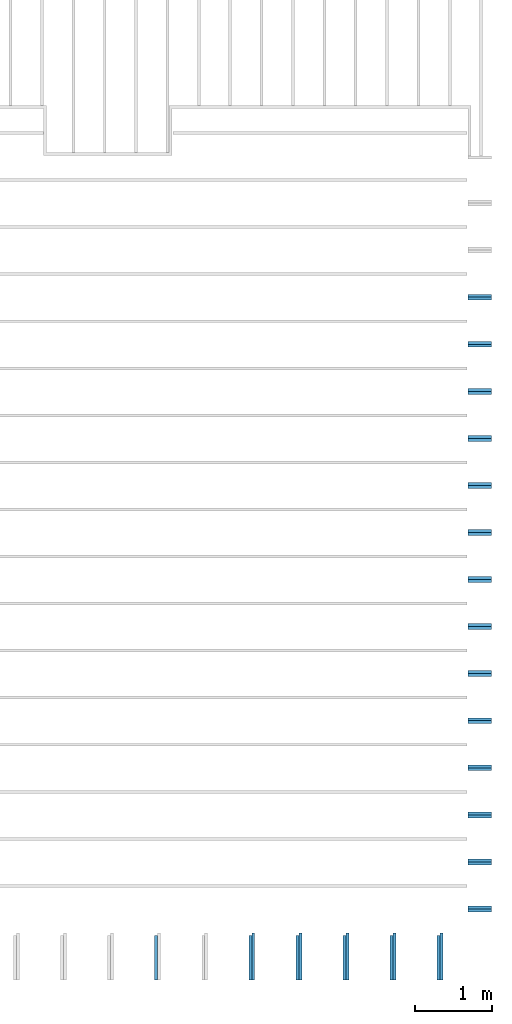
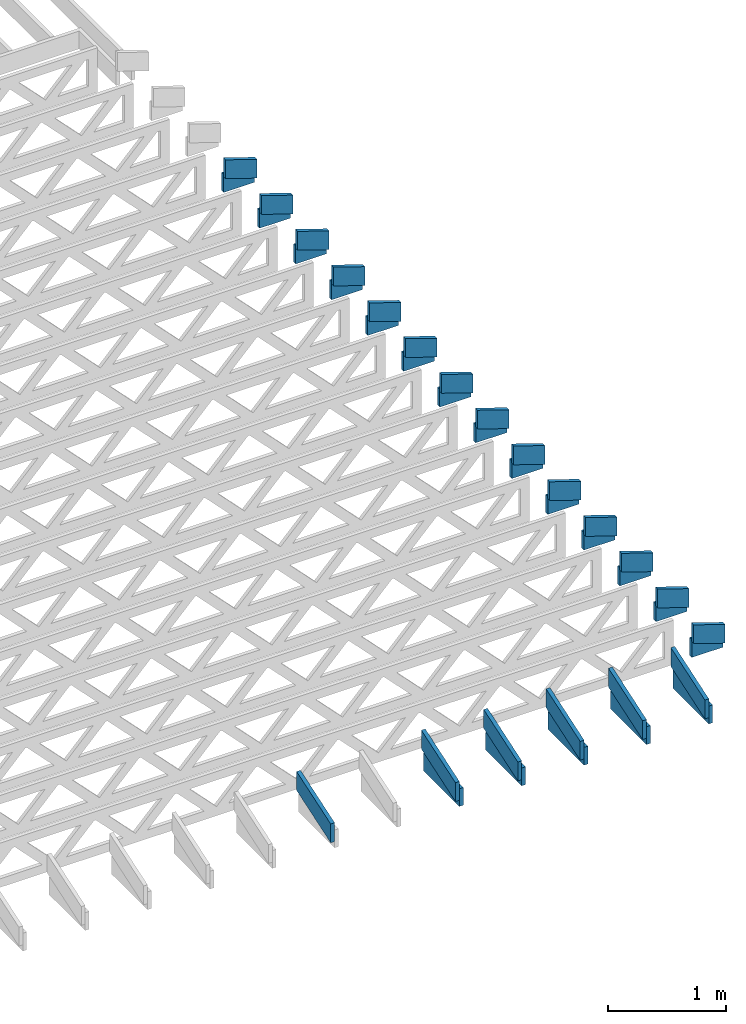
# One storey, part 16 of 18: 39 beams, 4 elements without a shape of their own.
"""IFC4 building model written with IfcOpenShell, lengths in feet."""

from ifc_helpers import new_model, entity, si_unit, converted_unit, derived_unit, direction, frame, frame_2d, origin, origin_2d_with_axis, place, context, subcontext, project, spatial, rectangle, extrude, clip, halfspace, source, transform, mapped, material, material_profile, profile_set, profile_usage, type_object, type_shapes, element, aggregate, save


model = new_model("IFC4")

# Units and contexts
model_context_1 = context("Model", 3, precision=0.0001, world=origin(), true_north=direction((6.12303176911189e-17, 1.0)))
model_context_2 = context("Model", 3, precision=0.0001, world=origin(), true_north=direction((6.12303176911189e-17, 1.0)))
body_context = subcontext(model_context_2, "Body", "Model", "MODEL_VIEW")
ifc_project = project(units=[converted_unit("LENGTHUNIT", "FOOT", entity("IfcRatioMeasure", 0.3048), si_unit("LENGTHUNIT", "METRE"), dimensions=[1, 0, 0, 0, 0, 0, 0]), converted_unit("AREAUNIT", "SQUARE FOOT", entity("IfcRatioMeasure", 0.09290304), si_unit("AREAUNIT", "SQUARE_METRE"), dimensions=[2, 0, 0, 0, 0, 0, 0]), converted_unit("VOLUMEUNIT", "CUBIC FOOT", entity("IfcRatioMeasure", 0.028316846592), si_unit("VOLUMEUNIT", "CUBIC_METRE"), dimensions=[3, 0, 0, 0, 0, 0, 0]), converted_unit("PLANEANGLEUNIT", "DEGREE", entity("IfcRatioMeasure", 0.0174532925199433), si_unit("PLANEANGLEUNIT", "RADIAN"), dimensions=[0, 0, 0, 0, 0, 0, 0]), si_unit("MASSUNIT", "GRAM", prefix="KILO"), derived_unit("MASSDENSITYUNIT", [(si_unit("MASSUNIT", "GRAM", prefix="KILO"), 1), (si_unit("LENGTHUNIT", "METRE"), -3)]), derived_unit("MOMENTOFINERTIAUNIT", [(si_unit("LENGTHUNIT", "METRE"), 4)]), si_unit("TIMEUNIT", "SECOND"), si_unit("FREQUENCYUNIT", "HERTZ"), si_unit("THERMODYNAMICTEMPERATUREUNIT", "DEGREE_CELSIUS"), derived_unit("THERMALTRANSMITTANCEUNIT", [(si_unit("MASSUNIT", "GRAM", prefix="KILO"), 1), (si_unit("THERMODYNAMICTEMPERATUREUNIT", "KELVIN"), -1), (si_unit("TIMEUNIT", "SECOND"), -3)]), derived_unit("VOLUMETRICFLOWRATEUNIT", [(si_unit("LENGTHUNIT", "METRE"), 3), (si_unit("TIMEUNIT", "SECOND"), -1)]), si_unit("ELECTRICCURRENTUNIT", "AMPERE"), si_unit("ELECTRICVOLTAGEUNIT", "VOLT"), si_unit("POWERUNIT", "WATT"), si_unit("FORCEUNIT", "NEWTON"), si_unit("ILLUMINANCEUNIT", "LUX"), si_unit("LUMINOUSFLUXUNIT", "LUMEN"), si_unit("LUMINOUSINTENSITYUNIT", "CANDELA"), derived_unit("USERDEFINED", [(si_unit("MASSUNIT", "GRAM", prefix="KILO"), -1), (si_unit("LENGTHUNIT", "METRE"), -2), (si_unit("TIMEUNIT", "SECOND"), 3), (si_unit("LUMINOUSFLUXUNIT", "LUMEN"), 1)]), derived_unit("LINEARVELOCITYUNIT", [(si_unit("LENGTHUNIT", "METRE"), 1), (si_unit("TIMEUNIT", "SECOND"), -1)]), si_unit("PRESSUREUNIT", "PASCAL"), derived_unit("USERDEFINED", [(si_unit("LENGTHUNIT", "METRE"), -2), (si_unit("MASSUNIT", "GRAM", prefix="KILO"), 1), (si_unit("TIMEUNIT", "SECOND"), -2)]), derived_unit("LINEARFORCEUNIT", [(si_unit("MASSUNIT", "GRAM", prefix="KILO"), 1), (si_unit("LENGTHUNIT", "METRE"), 1), (si_unit("TIMEUNIT", "SECOND"), -2), (si_unit("LENGTHUNIT", "METRE"), -1)]), derived_unit("PLANARFORCEUNIT", [(si_unit("MASSUNIT", "GRAM", prefix="KILO"), 1), (si_unit("LENGTHUNIT", "METRE"), 1), (si_unit("TIMEUNIT", "SECOND"), -2), (si_unit("LENGTHUNIT", "METRE"), -2)])], contexts=[model_context_1])

# Site, building, storey
site_placement = place(None, origin())
site = spatial("IfcSite", under=ifc_project, at=site_placement, CompositionType="ELEMENT")
building_placement = place(site_placement, origin())
building = spatial("IfcBuilding", under=site, at=building_placement, CompositionType="ELEMENT")
storey_placement = place(building_placement, frame((0.0, 0.0, 30.4375000000082)))
storey = spatial("IfcBuildingStorey", under=building, at=storey_placement, Name="ROOF", CompositionType="ELEMENT", Elevation=30.4375000000082)

# Assembly, beams
assembly_1_placement = place(storey_placement, origin())
assembly_1 = element("IfcElementAssembly", 1, at=assembly_1_placement, inside=storey, Name="Structural Beam System:Structural Framing System", ObjectType="Structural Beam System:Structural Framing System", AssemblyPlace="NOTDEFINED", PredefinedType="BEAM_GRID")
ifc_material_1 = material(Name="BOTTOM CHORD OF FIELD FRAMED OVERHANG", Category="Materials")
ifc_material_profile_1 = material_profile(ifc_material_1, rectangle(XDim=0.604166666666667, YDim=0.125000000000011, at=origin_2d_with_axis()), Name="2X8 - BOTTOM CHORD")
ifc_profile_set_1 = profile_set([ifc_material_profile_1], Name="2X8 - BOTTOM CHORD")
ifc_profile_usage_1 = profile_usage(ifc_profile_set_1, cardinal=8)
beam_type_1 = type_object("IfcBeamType", Name="061100 - Wood Framing:2X8 - BOTTOM CHORD", PredefinedType="BEAM", material=ifc_profile_set_1)
shared_shape_1 = source(origin(), body_context, "Body", "SweptSolid", [
    extrude(rectangle(XDim=0.604166666666667, YDim=0.125000000000011, at=origin_2d_with_axis()), frame((-1.0, 0.0, 0.0), z_axis=(1.0, 0.0, 0.0), x_axis=(0.0, 0.0, -1.0)), (0.0, 0.0, 1.0), 1.9999999999992),
])
type_shapes(beam_type_1, [shared_shape_1])
beam_1_placement = place(assembly_1_placement, frame((-149.488158437574, 922.861948345447, 1.07291666665406), z_axis=(0.0, 0.0, 1.0), x_axis=(0.0, -1.0, 0.0)))
beam_1 = element("IfcBeam", 2, at=beam_1_placement, type_object=beam_type_1, material=ifc_profile_usage_1, Name="061100 - Wood Framing:2X8 - BOTTOM CHORD", ObjectType="061100 - Wood Framing:2X8 - BOTTOM CHORD", PredefinedType="BEAM", context=body_context, shape_type="MappedRepresentation", body=[
    mapped(shared_shape_1, transform((0.0, 0.0, 0.0), scale=1.0)),
])
ifc_profile_usage_2 = profile_usage(ifc_profile_set_1, cardinal=8)
beam_2_placement = place(assembly_1_placement, frame((-147.488158437574, 922.86194884795, 1.07291666665406), z_axis=(0.0, 0.0, 1.0), x_axis=(0.0, -1.0, 0.0)))
beam_2 = element("IfcBeam", 3, at=beam_2_placement, type_object=beam_type_1, material=ifc_profile_usage_2, Name="061100 - Wood Framing:2X8 - BOTTOM CHORD", ObjectType="061100 - Wood Framing:2X8 - BOTTOM CHORD", PredefinedType="BEAM", context=body_context, shape_type="MappedRepresentation", body=[
    mapped(shared_shape_1, transform((0.0, 0.0, 0.0), scale=1.0)),
])
ifc_profile_usage_3 = profile_usage(ifc_profile_set_1, cardinal=8)
beam_3_placement = place(assembly_1_placement, frame((-143.488158437574, 922.861949852958, 1.07291666665406), z_axis=(0.0, 0.0, 1.0), x_axis=(0.0, -1.0, 0.0)))
beam_3 = element("IfcBeam", 4, at=beam_3_placement, type_object=beam_type_1, material=ifc_profile_usage_3, Name="061100 - Wood Framing:2X8 - BOTTOM CHORD", ObjectType="061100 - Wood Framing:2X8 - BOTTOM CHORD", PredefinedType="BEAM", context=body_context, shape_type="MappedRepresentation", body=[
    mapped(shared_shape_1, transform((0.0, 0.0, 0.0), scale=1.0)),
])
ifc_profile_usage_4 = profile_usage(ifc_profile_set_1, cardinal=8)
beam_4_placement = place(assembly_1_placement, frame((-141.488158437574, 922.861950355462, 1.07291666665406), z_axis=(0.0, 0.0, 1.0), x_axis=(0.0, -1.0, 0.0)))
beam_4 = element("IfcBeam", 5, at=beam_4_placement, type_object=beam_type_1, material=ifc_profile_usage_4, Name="061100 - Wood Framing:2X8 - BOTTOM CHORD", ObjectType="061100 - Wood Framing:2X8 - BOTTOM CHORD", PredefinedType="BEAM", context=body_context, shape_type="MappedRepresentation", body=[
    mapped(shared_shape_1, transform((0.0, 0.0, 0.0), scale=1.0)),
])
ifc_profile_usage_5 = profile_usage(ifc_profile_set_1, cardinal=8)
beam_5_placement = place(assembly_1_placement, frame((-145.488158437574, 922.861949350454, 1.07291666665406), z_axis=(0.0, 0.0, 1.0), x_axis=(0.0, -1.0, 0.0)))
beam_5 = element("IfcBeam", 6, at=beam_5_placement, type_object=beam_type_1, material=ifc_profile_usage_5, Name="061100 - Wood Framing:2X8 - BOTTOM CHORD", ObjectType="061100 - Wood Framing:2X8 - BOTTOM CHORD", PredefinedType="BEAM", context=body_context, shape_type="MappedRepresentation", body=[
    mapped(shared_shape_1, transform((0.0, 0.0, 0.0), scale=1.0)),
])
aggregate(assembly_1, [beam_1, beam_2, beam_3, beam_4, beam_5])

assembly_2_placement = place(storey_placement, origin())
assembly_2 = element("IfcElementAssembly", 7, at=assembly_2_placement, inside=storey, Name="Structural Beam System:Structural Framing System", ObjectType="Structural Beam System:Structural Framing System", AssemblyPlace="NOTDEFINED", PredefinedType="BEAM_GRID")
ifc_material_2 = material(Name="TOP CHORD OF FIELD FRAMED OVERHANG", Category="Materials")
ifc_material_profile_2 = material_profile(ifc_material_2, rectangle(XDim=0.604166666666667, YDim=0.125, at=origin_2d_with_axis()), Name="2X8 TOP CHORD")
ifc_profile_set_2 = profile_set([ifc_material_profile_2], Name="2X8 TOP CHORD")
ifc_profile_usage_6 = profile_usage(ifc_profile_set_2, cardinal=8)
beam_type_2 = type_object("IfcBeamType", Name="Dimension Lumber - Ends:2X8 TOP CHORD", PredefinedType="BEAM", material=ifc_profile_set_2)
shared_shape_2 = source(origin(), body_context, "Body", "Clipping", [
    clip(clip(extrude(rectangle(XDim=0.604166666666667, YDim=0.125, at=origin_2d_with_axis()), frame((-0.999187080503646, 0.0, 0.0), z_axis=(1.0, 0.0, 0.0), x_axis=(0.0, 0.0, -1.0)), (0.0, 0.0, 1.0), 2.19970506951975), halfspace(frame((0.999187080503609, -0.0625000000000025, -0.302083333333339), z_axis=(0.948710608132914, 0.0, -0.316145823973805), x_axis=(0.0, 1.0, 0.0)), False)), halfspace(frame((-0.797856171991158, -0.0625000000000025, 0.302083333333328), z_axis=(-0.948710608132914, 0.0, 0.316145823973806), x_axis=(0.0, 1.0, 0.0)), False)),
])
type_shapes(beam_type_2, [shared_shape_2])
beam_6_placement = place(assembly_2_placement, frame((-149.613159217447, 922.714304085524, 1.58619153801158), z_axis=(0.0, -0.316227766016849, 0.94868329805051), x_axis=(0.0, 0.94868329805051, 0.316227766016849)))
beam_6 = element("IfcBeam", 8, at=beam_6_placement, type_object=beam_type_2, material=ifc_profile_usage_6, Name="Dimension Lumber - Ends:2X8 TOP CHORD", ObjectType="Dimension Lumber - Ends:2X8 TOP CHORD", PredefinedType="BEAM", context=body_context, shape_type="MappedRepresentation", body=[
    mapped(shared_shape_2, transform((0.0, 0.0, 0.0), scale=1.0)),
])
ifc_profile_usage_7 = profile_usage(ifc_profile_set_2, cardinal=8)
beam_7_placement = place(assembly_2_placement, frame((-143.613159217447, 922.714304085524, 1.58619153801158), z_axis=(0.0, -0.316227766016852, 0.948683298050509), x_axis=(0.0, 0.948683298050509, 0.316227766016852)))
beam_7 = element("IfcBeam", 9, at=beam_7_placement, type_object=beam_type_2, material=ifc_profile_usage_7, Name="Dimension Lumber - Ends:2X8 TOP CHORD", ObjectType="Dimension Lumber - Ends:2X8 TOP CHORD", PredefinedType="BEAM", context=body_context, shape_type="MappedRepresentation", body=[
    mapped(shared_shape_2, transform((0.0, 0.0, 0.0), scale=1.0)),
])
ifc_profile_usage_8 = profile_usage(ifc_profile_set_2, cardinal=8)
beam_8_placement = place(assembly_2_placement, frame((-141.613159217447, 922.714304085524, 1.58619153801152), z_axis=(0.0, -0.316227766016851, 0.94868329805051), x_axis=(0.0, 0.94868329805051, 0.316227766016851)))
beam_8 = element("IfcBeam", 10, at=beam_8_placement, type_object=beam_type_2, material=ifc_profile_usage_8, Name="Dimension Lumber - Ends:2X8 TOP CHORD", ObjectType="Dimension Lumber - Ends:2X8 TOP CHORD", PredefinedType="BEAM", context=body_context, shape_type="MappedRepresentation", body=[
    mapped(shared_shape_2, transform((0.0, 0.0, 0.0), scale=1.0)),
])
ifc_profile_usage_9 = profile_usage(ifc_profile_set_2, cardinal=8)
beam_9_placement = place(assembly_2_placement, frame((-145.613159217447, 922.714304085524, 1.58619153801152), z_axis=(0.0, -0.316227766016851, 0.94868329805051), x_axis=(0.0, 0.94868329805051, 0.316227766016851)))
beam_9 = element("IfcBeam", 11, at=beam_9_placement, type_object=beam_type_2, material=ifc_profile_usage_9, Name="Dimension Lumber - Ends:2X8 TOP CHORD", ObjectType="Dimension Lumber - Ends:2X8 TOP CHORD", PredefinedType="BEAM", context=body_context, shape_type="MappedRepresentation", body=[
    mapped(shared_shape_2, transform((0.0, 0.0, 0.0), scale=1.0)),
])
ifc_profile_usage_10 = profile_usage(ifc_profile_set_2, cardinal=8)
beam_10_placement = place(assembly_2_placement, frame((-147.613159217447, 922.714304085524, 1.58619153801152), z_axis=(0.0, -0.316227766016851, 0.94868329805051), x_axis=(0.0, 0.94868329805051, 0.316227766016851)))
beam_10 = element("IfcBeam", 12, at=beam_10_placement, type_object=beam_type_2, material=ifc_profile_usage_10, Name="Dimension Lumber - Ends:2X8 TOP CHORD", ObjectType="Dimension Lumber - Ends:2X8 TOP CHORD", PredefinedType="BEAM", context=body_context, shape_type="MappedRepresentation", body=[
    mapped(shared_shape_2, transform((0.0, 0.0, 0.0), scale=1.0)),
])
ifc_profile_usage_11 = profile_usage(ifc_profile_set_2, cardinal=8)
beam_11_placement = place(assembly_2_placement, frame((-153.613159217447, 922.714304085524, 1.58619153801158), z_axis=(0.0, -0.316227766016849, 0.94868329805051), x_axis=(0.0, 0.94868329805051, 0.316227766016849)))
beam_11 = element("IfcBeam", 13, at=beam_11_placement, type_object=beam_type_2, material=ifc_profile_usage_11, Name="Dimension Lumber - Ends:2X8 TOP CHORD", ObjectType="Dimension Lumber - Ends:2X8 TOP CHORD", PredefinedType="BEAM", context=body_context, shape_type="MappedRepresentation", body=[
    mapped(shared_shape_2, transform((0.0, 0.0, 0.0), scale=1.0)),
])
aggregate(assembly_2, [beam_6, beam_7, beam_8, beam_9, beam_10, beam_11])

assembly_3_placement = place(storey_placement, origin())
assembly_3 = element("IfcElementAssembly", 14, at=assembly_3_placement, inside=storey, Name="Structural Beam System:Structural Framing System", ObjectType="Structural Beam System:Structural Framing System", AssemblyPlace="NOTDEFINED", PredefinedType="BEAM_GRID")
ifc_profile_usage_12 = profile_usage(ifc_profile_set_1, cardinal=8)
beam_type_3 = type_object("IfcBeamType", Name="061100 - Wood Framing:2X8 - BOTTOM CHORD", PredefinedType="BEAM", material=ifc_profile_set_1)
shared_shape_3 = source(origin(), body_context, "Body", "SweptSolid", [
    extrude(rectangle(XDim=0.604166666666667, YDim=0.125000000000011, at=origin_2d_with_axis()), frame((-0.497179684451055, 0.0, 0.0), z_axis=(1.0, 0.0, 0.0), x_axis=(0.0, 0.0, -1.0)), (0.0, 0.0, 1.0), 0.99435936890211),
])
type_shapes(beam_type_3, [shared_shape_3])
beam_12_placement = place(assembly_3_placement, frame((-139.855564134411, 924.945268401832, 1.07291666665407)))
beam_12 = element("IfcBeam", 15, at=beam_12_placement, type_object=beam_type_3, material=ifc_profile_usage_12, Name="061100 - Wood Framing:2X8 - BOTTOM CHORD", ObjectType="061100 - Wood Framing:2X8 - BOTTOM CHORD", PredefinedType="BEAM", context=body_context, shape_type="MappedRepresentation", body=[
    mapped(shared_shape_3, transform((0.0, 0.0, 0.0), scale=1.0)),
])
ifc_profile_usage_13 = profile_usage(ifc_profile_set_1, cardinal=8)
beam_13_placement = place(assembly_3_placement, frame((-139.855564134411, 930.945268401832, 1.07291666665407)))
beam_13 = element("IfcBeam", 16, at=beam_13_placement, type_object=beam_type_3, material=ifc_profile_usage_13, Name="061100 - Wood Framing:2X8 - BOTTOM CHORD", ObjectType="061100 - Wood Framing:2X8 - BOTTOM CHORD", PredefinedType="BEAM", context=body_context, shape_type="MappedRepresentation", body=[
    mapped(shared_shape_3, transform((0.0, 0.0, 0.0), scale=1.0)),
])
ifc_profile_usage_14 = profile_usage(ifc_profile_set_1, cardinal=8)
beam_14_placement = place(assembly_3_placement, frame((-139.855564134411, 932.945268401832, 1.07291666665407)))
beam_14 = element("IfcBeam", 17, at=beam_14_placement, type_object=beam_type_3, material=ifc_profile_usage_14, Name="061100 - Wood Framing:2X8 - BOTTOM CHORD", ObjectType="061100 - Wood Framing:2X8 - BOTTOM CHORD", PredefinedType="BEAM", context=body_context, shape_type="MappedRepresentation", body=[
    mapped(shared_shape_3, transform((0.0, 0.0, 0.0), scale=1.0)),
])
ifc_profile_usage_15 = profile_usage(ifc_profile_set_1, cardinal=8)
beam_15_placement = place(assembly_3_placement, frame((-139.855564134411, 934.945268401832, 1.07291666665407)))
beam_15 = element("IfcBeam", 18, at=beam_15_placement, type_object=beam_type_3, material=ifc_profile_usage_15, Name="061100 - Wood Framing:2X8 - BOTTOM CHORD", ObjectType="061100 - Wood Framing:2X8 - BOTTOM CHORD", PredefinedType="BEAM", context=body_context, shape_type="MappedRepresentation", body=[
    mapped(shared_shape_3, transform((0.0, 0.0, 0.0), scale=1.0)),
])
ifc_profile_usage_16 = profile_usage(ifc_profile_set_1, cardinal=8)
beam_16_placement = place(assembly_3_placement, frame((-139.855564134411, 936.945268401832, 1.07291666665407)))
beam_16 = element("IfcBeam", 19, at=beam_16_placement, type_object=beam_type_3, material=ifc_profile_usage_16, Name="061100 - Wood Framing:2X8 - BOTTOM CHORD", ObjectType="061100 - Wood Framing:2X8 - BOTTOM CHORD", PredefinedType="BEAM", context=body_context, shape_type="MappedRepresentation", body=[
    mapped(shared_shape_3, transform((0.0, 0.0, 0.0), scale=1.0)),
])
ifc_profile_usage_17 = profile_usage(ifc_profile_set_1, cardinal=8)
beam_17_placement = place(assembly_3_placement, frame((-139.855564134411, 942.945268401832, 1.07291666665407)))
beam_17 = element("IfcBeam", 20, at=beam_17_placement, type_object=beam_type_3, material=ifc_profile_usage_17, Name="061100 - Wood Framing:2X8 - BOTTOM CHORD", ObjectType="061100 - Wood Framing:2X8 - BOTTOM CHORD", PredefinedType="BEAM", context=body_context, shape_type="MappedRepresentation", body=[
    mapped(shared_shape_3, transform((0.0, 0.0, 0.0), scale=1.0)),
])
ifc_profile_usage_18 = profile_usage(ifc_profile_set_1, cardinal=8)
beam_18_placement = place(assembly_3_placement, frame((-139.855564134411, 946.945268401832, 1.07291666665407)))
beam_18 = element("IfcBeam", 21, at=beam_18_placement, type_object=beam_type_3, material=ifc_profile_usage_18, Name="061100 - Wood Framing:2X8 - BOTTOM CHORD", ObjectType="061100 - Wood Framing:2X8 - BOTTOM CHORD", PredefinedType="BEAM", context=body_context, shape_type="MappedRepresentation", body=[
    mapped(shared_shape_3, transform((0.0, 0.0, 0.0), scale=1.0)),
])
ifc_profile_usage_19 = profile_usage(ifc_profile_set_1, cardinal=8)
beam_19_placement = place(assembly_3_placement, frame((-139.855564134411, 926.945268401832, 1.07291666665407)))
beam_19 = element("IfcBeam", 22, at=beam_19_placement, type_object=beam_type_3, material=ifc_profile_usage_19, Name="061100 - Wood Framing:2X8 - BOTTOM CHORD", ObjectType="061100 - Wood Framing:2X8 - BOTTOM CHORD", PredefinedType="BEAM", context=body_context, shape_type="MappedRepresentation", body=[
    mapped(shared_shape_3, transform((0.0, 0.0, 0.0), scale=1.0)),
])
ifc_profile_usage_20 = profile_usage(ifc_profile_set_1, cardinal=8)
beam_20_placement = place(assembly_3_placement, frame((-139.855564134411, 938.945268401832, 1.07291666665407)))
beam_20 = element("IfcBeam", 23, at=beam_20_placement, type_object=beam_type_3, material=ifc_profile_usage_20, Name="061100 - Wood Framing:2X8 - BOTTOM CHORD", ObjectType="061100 - Wood Framing:2X8 - BOTTOM CHORD", PredefinedType="BEAM", context=body_context, shape_type="MappedRepresentation", body=[
    mapped(shared_shape_3, transform((0.0, 0.0, 0.0), scale=1.0)),
])
ifc_profile_usage_21 = profile_usage(ifc_profile_set_1, cardinal=8)
beam_21_placement = place(assembly_3_placement, frame((-139.855564134411, 940.945268401832, 1.07291666665407)))
beam_21 = element("IfcBeam", 24, at=beam_21_placement, type_object=beam_type_3, material=ifc_profile_usage_21, Name="061100 - Wood Framing:2X8 - BOTTOM CHORD", ObjectType="061100 - Wood Framing:2X8 - BOTTOM CHORD", PredefinedType="BEAM", context=body_context, shape_type="MappedRepresentation", body=[
    mapped(shared_shape_3, transform((0.0, 0.0, 0.0), scale=1.0)),
])
ifc_profile_usage_22 = profile_usage(ifc_profile_set_1, cardinal=8)
beam_22_placement = place(assembly_3_placement, frame((-139.855564134411, 944.945268401832, 1.07291666665407)))
beam_22 = element("IfcBeam", 25, at=beam_22_placement, type_object=beam_type_3, material=ifc_profile_usage_22, Name="061100 - Wood Framing:2X8 - BOTTOM CHORD", ObjectType="061100 - Wood Framing:2X8 - BOTTOM CHORD", PredefinedType="BEAM", context=body_context, shape_type="MappedRepresentation", body=[
    mapped(shared_shape_3, transform((0.0, 0.0, 0.0), scale=1.0)),
])
ifc_profile_usage_23 = profile_usage(ifc_profile_set_1, cardinal=8)
beam_23_placement = place(assembly_3_placement, frame((-139.855564134411, 948.945268401832, 1.07291666665407)))
beam_23 = element("IfcBeam", 26, at=beam_23_placement, type_object=beam_type_3, material=ifc_profile_usage_23, Name="061100 - Wood Framing:2X8 - BOTTOM CHORD", ObjectType="061100 - Wood Framing:2X8 - BOTTOM CHORD", PredefinedType="BEAM", context=body_context, shape_type="MappedRepresentation", body=[
    mapped(shared_shape_3, transform((0.0, 0.0, 0.0), scale=1.0)),
])
ifc_profile_usage_24 = profile_usage(ifc_profile_set_1, cardinal=8)
beam_24_placement = place(assembly_3_placement, frame((-139.855564134411, 928.945268401832, 1.07291666665407)))
beam_24 = element("IfcBeam", 27, at=beam_24_placement, type_object=beam_type_3, material=ifc_profile_usage_24, Name="061100 - Wood Framing:2X8 - BOTTOM CHORD", ObjectType="061100 - Wood Framing:2X8 - BOTTOM CHORD", PredefinedType="BEAM", context=body_context, shape_type="MappedRepresentation", body=[
    mapped(shared_shape_3, transform((0.0, 0.0, 0.0), scale=1.0)),
])
ifc_profile_usage_25 = profile_usage(ifc_profile_set_1, cardinal=8)
beam_25_placement = place(assembly_3_placement, frame((-139.855564134411, 950.945268401832, 1.07291666665407)))
beam_25 = element("IfcBeam", 28, at=beam_25_placement, type_object=beam_type_3, material=ifc_profile_usage_25, Name="061100 - Wood Framing:2X8 - BOTTOM CHORD", ObjectType="061100 - Wood Framing:2X8 - BOTTOM CHORD", PredefinedType="BEAM", context=body_context, shape_type="MappedRepresentation", body=[
    mapped(shared_shape_3, transform((0.0, 0.0, 0.0), scale=1.0)),
])
aggregate(assembly_3, [beam_12, beam_13, beam_14, beam_15, beam_16, beam_17, beam_18, beam_19, beam_20, beam_21, beam_22, beam_23, beam_24, beam_25])

assembly_4_placement = place(storey_placement, origin())
assembly_4 = element("IfcElementAssembly", 29, at=assembly_4_placement, inside=storey, Name="Structural Beam System:Structural Framing System", ObjectType="Structural Beam System:Structural Framing System", AssemblyPlace="NOTDEFINED", PredefinedType="BEAM_GRID")
ifc_profile_usage_26 = profile_usage(ifc_profile_set_2, cardinal=8)
beam_type_4 = type_object("IfcBeamType", Name="Dimension Lumber - Ends:2X8 TOP CHORD", PredefinedType="BEAM", material=ifc_profile_set_2)
shared_shape_4 = source(origin(), body_context, "Body", "Clipping", [
    clip(clip(extrude(rectangle(XDim=0.604166666666671, YDim=0.125, at=frame_2d((-1.52655665885959e-15, 0.0), x_axis=(1.0, 0.0))), frame((-0.529560098375526, 0.0, 0.0), z_axis=(1.0, 0.0, 0.0), x_axis=(0.0, 0.0, -1.0)), (0.0, 0.0, 1.0), 1.26045110526351), halfspace(frame((0.529560098375489, -0.0625000000000025, -0.302083333333339), z_axis=(0.948710608132914, 0.0, -0.316145823973805), x_axis=(0.0, 1.0, 0.0)), False)), halfspace(frame((-0.328229189863038, -0.0625000000000025, 0.302083333333328), z_axis=(-0.948710608132914, 0.0, 0.316145823973805), x_axis=(0.0, 1.0, 0.0)), False)),
])
type_shapes(beam_type_4, [shared_shape_4])
beam_26_placement = place(assembly_4_placement, frame((-139.765291953278, 924.820268401833, 1.43770432947392), z_axis=(0.316227766016836, 0.0, 0.948683298050515), x_axis=(-0.948683298050516, 0.0, 0.316227766016833)))
beam_26 = element("IfcBeam", 30, at=beam_26_placement, type_object=beam_type_4, material=ifc_profile_usage_26, Name="Dimension Lumber - Ends:2X8 TOP CHORD", ObjectType="Dimension Lumber - Ends:2X8 TOP CHORD", PredefinedType="BEAM", context=body_context, shape_type="MappedRepresentation", body=[
    mapped(shared_shape_4, transform((0.0, 0.0, 0.0), scale=1.0)),
])
ifc_profile_usage_27 = profile_usage(ifc_profile_set_2, cardinal=8)
beam_27_placement = place(assembly_4_placement, frame((-139.765291953278, 926.820268401833, 1.43770432947396), z_axis=(0.316227766016839, 0.0, 0.948683298050514), x_axis=(-0.948683298050515, 0.0, 0.316227766016836)))
beam_27 = element("IfcBeam", 31, at=beam_27_placement, type_object=beam_type_4, material=ifc_profile_usage_27, Name="Dimension Lumber - Ends:2X8 TOP CHORD", ObjectType="Dimension Lumber - Ends:2X8 TOP CHORD", PredefinedType="BEAM", context=body_context, shape_type="MappedRepresentation", body=[
    mapped(shared_shape_4, transform((0.0, 0.0, 0.0), scale=1.0)),
])
ifc_profile_usage_28 = profile_usage(ifc_profile_set_2, cardinal=8)
beam_28_placement = place(assembly_4_placement, frame((-139.765291953277, 930.820268401833, 1.43770432947471), z_axis=(0.316227766016833, 0.0, 0.948683298050516), x_axis=(-0.948683298050515, 0.0, 0.316227766016836)))
beam_28 = element("IfcBeam", 32, at=beam_28_placement, type_object=beam_type_4, material=ifc_profile_usage_28, Name="Dimension Lumber - Ends:2X8 TOP CHORD", ObjectType="Dimension Lumber - Ends:2X8 TOP CHORD", PredefinedType="BEAM", context=body_context, shape_type="MappedRepresentation", body=[
    mapped(shared_shape_4, transform((0.0, 0.0, 0.0), scale=1.0)),
])
ifc_profile_usage_29 = profile_usage(ifc_profile_set_2, cardinal=8)
beam_29_placement = place(assembly_4_placement, frame((-139.765291953278, 934.820268401833, 1.43770432947402), z_axis=(0.316227766016842, 0.0, 0.948683298050513), x_axis=(-0.948683298050514, 0.0, 0.316227766016839)))
beam_29 = element("IfcBeam", 33, at=beam_29_placement, type_object=beam_type_4, material=ifc_profile_usage_29, Name="Dimension Lumber - Ends:2X8 TOP CHORD", ObjectType="Dimension Lumber - Ends:2X8 TOP CHORD", PredefinedType="BEAM", context=body_context, shape_type="MappedRepresentation", body=[
    mapped(shared_shape_4, transform((0.0, 0.0, 0.0), scale=1.0)),
])
ifc_profile_usage_30 = profile_usage(ifc_profile_set_2, cardinal=8)
beam_30_placement = place(assembly_4_placement, frame((-139.765291953277, 944.820268401833, 1.43770432947485), z_axis=(0.316227766016833, 0.0, 0.948683298050516), x_axis=(-0.948683298050515, 0.0, 0.316227766016836)))
beam_30 = element("IfcBeam", 34, at=beam_30_placement, type_object=beam_type_4, material=ifc_profile_usage_30, Name="Dimension Lumber - Ends:2X8 TOP CHORD", ObjectType="Dimension Lumber - Ends:2X8 TOP CHORD", PredefinedType="BEAM", context=body_context, shape_type="MappedRepresentation", body=[
    mapped(shared_shape_4, transform((0.0, 0.0, 0.0), scale=1.0)),
])
ifc_profile_usage_31 = profile_usage(ifc_profile_set_2, cardinal=8)
beam_31_placement = place(assembly_4_placement, frame((-139.765291953277, 946.820268401833, 1.43770432947486), z_axis=(0.316227766016833, 0.0, 0.948683298050516), x_axis=(-0.948683298050515, 0.0, 0.316227766016836)))
beam_31 = element("IfcBeam", 35, at=beam_31_placement, type_object=beam_type_4, material=ifc_profile_usage_31, Name="Dimension Lumber - Ends:2X8 TOP CHORD", ObjectType="Dimension Lumber - Ends:2X8 TOP CHORD", PredefinedType="BEAM", context=body_context, shape_type="MappedRepresentation", body=[
    mapped(shared_shape_4, transform((0.0, 0.0, 0.0), scale=1.0)),
])
ifc_profile_usage_32 = profile_usage(ifc_profile_set_2, cardinal=8)
beam_32_placement = place(assembly_4_placement, frame((-139.765291953277, 950.820268401833, 1.43770432947488), z_axis=(0.31622776601683, 0.0, 0.948683298050517), x_axis=(-0.948683298050516, 0.0, 0.316227766016833)))
beam_32 = element("IfcBeam", 36, at=beam_32_placement, type_object=beam_type_4, material=ifc_profile_usage_32, Name="Dimension Lumber - Ends:2X8 TOP CHORD", ObjectType="Dimension Lumber - Ends:2X8 TOP CHORD", PredefinedType="BEAM", context=body_context, shape_type="MappedRepresentation", body=[
    mapped(shared_shape_4, transform((0.0, 0.0, 0.0), scale=1.0)),
])
ifc_profile_usage_33 = profile_usage(ifc_profile_set_2, cardinal=8)
beam_33_placement = place(assembly_4_placement, frame((-139.765291953278, 948.820268401833, 1.43770432947416), z_axis=(0.316227766016839, 0.0, 0.948683298050514), x_axis=(-0.948683298050515, 0.0, 0.316227766016836)))
beam_33 = element("IfcBeam", 37, at=beam_33_placement, type_object=beam_type_4, material=ifc_profile_usage_33, Name="Dimension Lumber - Ends:2X8 TOP CHORD", ObjectType="Dimension Lumber - Ends:2X8 TOP CHORD", PredefinedType="BEAM", context=body_context, shape_type="MappedRepresentation", body=[
    mapped(shared_shape_4, transform((0.0, 0.0, 0.0), scale=1.0)),
])
ifc_profile_usage_34 = profile_usage(ifc_profile_set_2, cardinal=8)
beam_34_placement = place(assembly_4_placement, frame((-139.765291953277, 942.820268401833, 1.43770432947483), z_axis=(0.316227766016833, 0.0, 0.948683298050516), x_axis=(-0.948683298050515, 0.0, 0.316227766016836)))
beam_34 = element("IfcBeam", 38, at=beam_34_placement, type_object=beam_type_4, material=ifc_profile_usage_34, Name="Dimension Lumber - Ends:2X8 TOP CHORD", ObjectType="Dimension Lumber - Ends:2X8 TOP CHORD", PredefinedType="BEAM", context=body_context, shape_type="MappedRepresentation", body=[
    mapped(shared_shape_4, transform((0.0, 0.0, 0.0), scale=1.0)),
])
ifc_profile_usage_35 = profile_usage(ifc_profile_set_2, cardinal=8)
beam_35_placement = place(assembly_4_placement, frame((-139.765291953278, 940.820268401833, 1.43770432947409), z_axis=(0.316227766016839, 0.0, 0.948683298050514), x_axis=(-0.948683298050515, 0.0, 0.316227766016836)))
beam_35 = element("IfcBeam", 39, at=beam_35_placement, type_object=beam_type_4, material=ifc_profile_usage_35, Name="Dimension Lumber - Ends:2X8 TOP CHORD", ObjectType="Dimension Lumber - Ends:2X8 TOP CHORD", PredefinedType="BEAM", context=body_context, shape_type="MappedRepresentation", body=[
    mapped(shared_shape_4, transform((0.0, 0.0, 0.0), scale=1.0)),
])
ifc_profile_usage_36 = profile_usage(ifc_profile_set_2, cardinal=8)
beam_36_placement = place(assembly_4_placement, frame((-139.765291953278, 938.820268401833, 1.43770432947406), z_axis=(0.316227766016842, 0.0, 0.948683298050513), x_axis=(-0.948683298050514, 0.0, 0.316227766016839)))
beam_36 = element("IfcBeam", 40, at=beam_36_placement, type_object=beam_type_4, material=ifc_profile_usage_36, Name="Dimension Lumber - Ends:2X8 TOP CHORD", ObjectType="Dimension Lumber - Ends:2X8 TOP CHORD", PredefinedType="BEAM", context=body_context, shape_type="MappedRepresentation", body=[
    mapped(shared_shape_4, transform((0.0, 0.0, 0.0), scale=1.0)),
])
ifc_profile_usage_37 = profile_usage(ifc_profile_set_2, cardinal=8)
beam_37_placement = place(assembly_4_placement, frame((-139.765291953278, 936.820268401833, 1.43770432947404), z_axis=(0.316227766016839, 0.0, 0.948683298050514), x_axis=(-0.948683298050515, 0.0, 0.316227766016836)))
beam_37 = element("IfcBeam", 41, at=beam_37_placement, type_object=beam_type_4, material=ifc_profile_usage_37, Name="Dimension Lumber - Ends:2X8 TOP CHORD", ObjectType="Dimension Lumber - Ends:2X8 TOP CHORD", PredefinedType="BEAM", context=body_context, shape_type="MappedRepresentation", body=[
    mapped(shared_shape_4, transform((0.0, 0.0, 0.0), scale=1.0)),
])
ifc_profile_usage_38 = profile_usage(ifc_profile_set_2, cardinal=8)
beam_38_placement = place(assembly_4_placement, frame((-139.765291953278, 932.820268401833, 1.43770432947401), z_axis=(0.316227766016842, 0.0, 0.948683298050513), x_axis=(-0.948683298050514, 0.0, 0.316227766016839)))
beam_38 = element("IfcBeam", 42, at=beam_38_placement, type_object=beam_type_4, material=ifc_profile_usage_38, Name="Dimension Lumber - Ends:2X8 TOP CHORD", ObjectType="Dimension Lumber - Ends:2X8 TOP CHORD", PredefinedType="BEAM", context=body_context, shape_type="MappedRepresentation", body=[
    mapped(shared_shape_4, transform((0.0, 0.0, 0.0), scale=1.0)),
])
ifc_profile_usage_39 = profile_usage(ifc_profile_set_2, cardinal=8)
beam_39_placement = place(assembly_4_placement, frame((-139.765291953278, 928.820268401833, 1.43770432947397), z_axis=(0.316227766016836, 0.0, 0.948683298050515), x_axis=(-0.948683298050516, 0.0, 0.316227766016833)))
beam_39 = element("IfcBeam", 43, at=beam_39_placement, type_object=beam_type_4, material=ifc_profile_usage_39, Name="Dimension Lumber - Ends:2X8 TOP CHORD", ObjectType="Dimension Lumber - Ends:2X8 TOP CHORD", PredefinedType="BEAM", context=body_context, shape_type="MappedRepresentation", body=[
    mapped(shared_shape_4, transform((0.0, 0.0, 0.0), scale=1.0)),
])
aggregate(assembly_4, [beam_26, beam_27, beam_28, beam_29, beam_30, beam_31, beam_32, beam_33, beam_34, beam_35, beam_36, beam_37, beam_38, beam_39])

save(model, "model.ifc")
